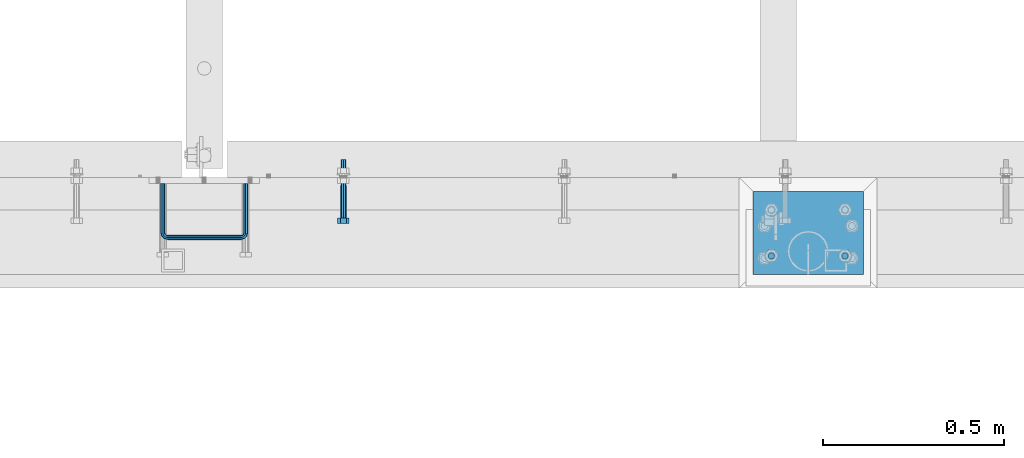
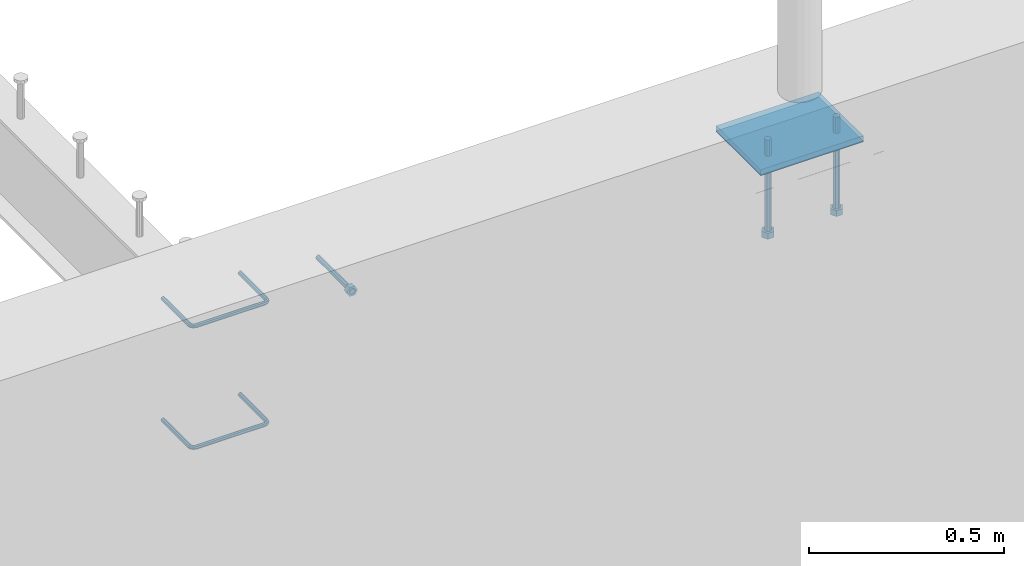
# One storey, part 402 of 975: 7 beams.
"""IFC2X3 building model written with IfcOpenShell, lengths in millimetres."""

from ifc_helpers import new_model, si_unit, frame, origin_with_axes, place, context, subcontext, project, spatial, faceted_brep, material, type_object, element, save


model = new_model("IFC2X3")

# Units and contexts
model_context = context("Model", 3, precision=1e-05, world=origin_with_axes())
body_context = subcontext(model_context, "Body", "Model", "MODEL_VIEW")
ifc_project = project(units=[si_unit("LENGTHUNIT", "METRE", prefix="MILLI"), si_unit("AREAUNIT", "SQUARE_METRE"), si_unit("VOLUMEUNIT", "CUBIC_METRE"), si_unit("MASSUNIT", "GRAM", prefix="KILO"), si_unit("TIMEUNIT", "SECOND"), si_unit("PLANEANGLEUNIT", "RADIAN"), si_unit("SOLIDANGLEUNIT", "STERADIAN"), si_unit("THERMODYNAMICTEMPERATUREUNIT", "DEGREE_CELSIUS"), si_unit("LUMINOUSINTENSITYUNIT", "LUMEN")], contexts=[model_context])

# Site, building, storey
site_placement = place(None, origin_with_axes())
site = spatial("IfcSite", under=ifc_project, at=site_placement, CompositionType="ELEMENT")
building_placement = place(site_placement, origin_with_axes())
building = spatial("IfcBuilding", under=site, at=building_placement, Name="Undefined", CompositionType="ELEMENT")
storey_placement = place(building_placement, origin_with_axes())
storey = spatial("IfcBuildingStorey", under=building, at=storey_placement, Name="Undefined", CompositionType="ELEMENT", Elevation=0.0)

# Beams
ifc_material_1 = material(Name="STEEL/F1554-36")
beam_type_1 = type_object("IfcBeamType", PredefinedType="NOTDEFINED")
beam_1_placement = place(storey_placement, frame((16405.225, 282.575000000001, 3886.2), z_axis=(0.0, 0.0, -1.0), x_axis=(0.0, -1.0, 0.0)))
element("IfcBeam", 1, at=beam_1_placement, inside=storey, type_object=beam_type_1, material=ifc_material_1, Name="HEADED_ANCHOR_BOLT", context=body_context, shape_type="Brep", body=[
    faceted_brep([(88.9000000184824, 7.94000001861696, -13.7499999799138), (88.8999999527368, 15.8800000758411, 2.00943759409711e-08), (104.774999952569, 15.8800001213949, 6.97191353538074e-08), (104.775000018315, 7.94000006417082, -13.7499999302891), (88.900000064019, -7.94000009583215, -13.7499999799147), (104.775000063852, -7.9400000502792, -13.74999993029), (88.9000000438027, -15.880000153059, 2.00925569515675e-08), (104.775000043643, -15.8800001075042, 6.9716406869702e-08), (88.8999999780608, -7.94000009583488, 13.7500000200998), (104.774999977893, -7.94000005028101, 13.7500000697237), (88.8999999325279, 7.94000001861514, 13.7500000201007), (104.774999932361, 7.940000064169, 13.7500000697246), (88.9000000119959, 3.78780480527439, -7.86545778426807), (88.8999999957159, 6.82538844544797, -5.4430656647246), (88.8999999799416, 8.51112018845743, -1.94260763148395), (88.8999999677944, 8.51112018845652, 1.94260767167179), (88.8999999616899, 6.82538844544615, 5.44306570491244), (88.8999999628249, 3.78780480527257, 7.86545782445592), (88.8999999709849, -3.86089595849626e-08, 8.72999956233434), (88.8999999845473, -3.7878048824914, 7.8654578244541), (88.9000000008309, -6.82538852266407, 5.44306570491153), (88.9000000166052, -8.51112026567444, 1.94260767166998), (88.9000000287488, -8.51112026567353, -1.94260763148577), (88.9000000348606, -6.82538852266407, -5.44306566472642), (88.9000000337182, -3.78780488248958, -7.86545778426898), (88.9000000255583, -3.86080500902608e-08, -8.72999952214832), (104.775000025395, 6.94581103743985e-09, -8.72999947252447), (104.775000011829, 3.78780485082825, -7.86545773464422), (104.774999995549, 6.82538849100092, -5.44306561510075), (104.774999979774, 8.51112023401038, -1.9426075818601), (104.774999967627, 8.51112023401038, 1.94260772129564), (104.774999961523, 6.82538849100092, 5.44306575453629), (104.774999962658, 3.78780485082643, 7.86545787407977), (104.774999970818, 6.94399204803631e-09, 8.7299996119591), (104.77499998438, -3.78780483693754, 7.86545787407886), (104.775000000664, -6.82538847711112, 5.44306575453538), (104.775000016438, -8.51112022012057, 1.94260772129473), (104.775000028581, -8.51112022012057, -1.94260758186101), (104.775000034693, -6.82538847711021, -5.44306561510166), (104.775000033551, -3.78780483693663, -7.86545773464422), (-2.99107341561466e-07, -5.61266007567065, 5.61266007566792), (-4.22995071858168e-07, -7.93750000000728, 0.0), (104.774999998088, -7.93749999999, -4.45652403868735e-11), (104.774999998088, -5.61266007565791, 5.61266007562426), (-1.09139364212751e-11, 1.81898940354586e-12, 7.9375), (104.774999998095, 1.18234311230481e-11, 7.93749999995816), (2.99089151667431e-07, 5.61266007567428, 5.61266007566792), (104.774999998102, 5.61266007568065, 5.61266007562517), (4.22980519942939e-07, 7.93750000001091, 0.0), (104.77499999811, 7.93750000001364, -4.36557456851006e-11), (2.99089151667431e-07, 5.61266007567428, -5.61266007566792), (104.774999998102, 5.61266007568156, -5.61266007571339), (-1.09139364212751e-11, 1.81898940354586e-12, -7.9375), (104.774999998099, 1.2732925824821e-11, -7.93750000004547), (-73.0249999592124, 5.05157065939329, -5.0515715445581), (-73.0249999269472, -1.85405951924622e-07, -7.14400069976364), (-73.0249999328516, -5.0515710302052, -5.05157154455992), (-73.0249999734697, -7.14400018541073, -6.9975976657588e-07), (-73.0250000250016, -5.05157103020611, 5.05157014504039), (-73.0250000572705, -1.85406861419324e-07, 7.1439993002441), (-73.0250000513661, 5.05157065939238, 5.05157014503948), (-73.025000010748, 7.14399981459792, -6.99758857081179e-07), (0.00625003290042514, 5.05157085007795, -5.05157087849238), (0.00625006516929716, 5.27870724909008e-09, -7.1440000336961), (0.00625005926485755, -5.05157083952145, -5.05157087849329), (0.00625001864682417, -7.14399999472516, -3.36940502165817e-08), (0.00624996711121639, -5.05157083952145, 5.05157081110519), (0.00624993484598235, 5.2777977543883e-09, 7.14399996631164), (0.00624994074678398, 5.05157085007704, 5.05157081110701), (0.00624998136845534, 7.14400000528167, -3.36922312271781e-08), (-2.99107341561466e-07, -5.61266007567065, -5.61266007566792), (104.774999998092, -5.612660075657, -5.6126600757143)], [[[0, 1, 2, 3]], [[4, 0, 3, 5]], [[6, 4, 5, 7]], [[8, 6, 7, 9]], [[10, 8, 9, 11]], [[0, 4, 6, 8, 10, 1], [12, 13, 14, 15, 16, 17, 18, 19, 20, 21, 22, 23, 24, 25]], [[12, 25, 26, 27]], [[13, 12, 27, 28]], [[14, 13, 28, 29]], [[15, 14, 29, 30]], [[16, 15, 30, 31]], [[17, 16, 31, 32]], [[18, 17, 32, 33]], [[19, 18, 33, 34]], [[20, 19, 34, 35]], [[21, 20, 35, 36]], [[22, 21, 36, 37]], [[23, 22, 37, 38]], [[24, 23, 38, 39]], [[25, 24, 39, 26]], [[9, 7, 5, 3, 2, 11], [38, 37, 36, 35, 34, 33, 32, 31, 30, 29, 28, 27, 26, 39]], [[1, 10, 11, 2]], [[40, 41, 42, 43]], [[44, 40, 43, 45]], [[46, 44, 45, 47]], [[48, 46, 47, 49]], [[50, 48, 49, 51]], [[52, 50, 51, 53]], [[54, 55, 56, 57, 58, 59, 60, 61]], [[55, 54, 62, 63]], [[56, 55, 63, 64]], [[57, 56, 64, 65]], [[58, 57, 65, 66]], [[59, 58, 66, 67]], [[60, 59, 67, 68]], [[61, 60, 68, 69]], [[54, 61, 69, 62]], [[40, 44, 46, 48, 50, 52, 70, 41], [68, 67, 66, 65, 64, 63, 62, 69]], [[41, 70, 71, 42]], [[53, 51, 49, 47, 45, 43, 42, 71]], [[70, 52, 53, 71]]]),
])
ifc_material_2 = material(Name="STEEL/A706")
beam_type_2 = type_object("IfcBeamType", Name="#4 TIE", PredefinedType="NOTDEFINED")
beam_2_placement = place(storey_placement, frame((16135.3500030518, 288.925, 3971.925), z_axis=(-0.999999999999998, 6.90000001668524e-08, 0.0), x_axis=(0.0, -1.0, 0.0)))
element("IfcBeam", 2, at=beam_2_placement, inside=storey, type_object=beam_type_2, material=ifc_material_2, Name="TIE ROD", ObjectType="#4 TIE", context=body_context, shape_type="Brep", body=[
    faceted_brep([(0.0, -6.34999999998763, -3.63797880709171e-12), (0.0, -4.49012806052269, -4.49012806054634), (136.525006144455, -4.49012806053452, -4.49012811661669), (136.525006146271, -6.35000000000036, -5.60821717954241e-08), (0.0, 7.27595761418343e-12, -6.35000000000764), (136.525006143703, 0.0, -6.35000005608254), (0.0, 4.49012806053724, -4.49012806053906), (136.525006144455, 4.49012806053452, -4.49012811661669), (0.0, 6.34999999999491, 5.45696821063757e-12), (136.525006146271, 6.35000000000036, -5.60821717954241e-08), (0.0, 4.49012806052633, 4.49012806054634), (136.525006148087, 4.49012806053452, 4.49012800445234), (0.0, 0.0, 6.35000000000764), (136.525006148839, 0.0, 6.34999994391819), (0.0, -4.49012806053361, 4.49012806053543), (136.525006148087, -4.49012806053452, 4.49012800445234), (146.050006113442, 0.0, -3.79778399058796), (145.120070138105, -4.49012806053452, -2.1870876464609), (142.875006094308, -6.35000000000036, 1.70147731239558), (140.62994205051, -4.49012806053452, 5.59004227125297), (139.700006075173, 0.0, 7.20073861538003), (140.62994205051, 4.49012806053452, 5.59004227125297), (142.875006094308, 6.35000000000036, 1.70147731239558), (145.120070138105, 4.49012806053452, -2.1870876464609), (151.412093644245, 4.49012806053452, 4.10493592790226), (153.022789998455, 0.0, 3.1749999700296), (147.523528661045, 6.35000000000036, 6.34999992953635), (143.634963677846, 4.49012806053452, 8.59506393117135), (142.024267323636, 0.0, 9.5249998890431), (143.634963677846, -4.49012806053452, 8.59506393117135), (147.523528661045, -6.35000000000036, 6.34999992953635), (151.412093644245, -4.49012806053452, 4.10493592790226), (153.715134021207, 4.49012806053452, 12.6999999465306), (155.575005960673, 0.0, 12.6999999674508), (149.225005960672, 6.35000000000036, 12.6999998960273), (144.734877900137, 4.49012806053452, 12.699999845524), (142.875005960672, 0.0, 12.6999998246056), (144.734877900137, -4.49012806053452, 12.699999845524), (149.225005960671, -6.35000000000036, 12.6999998960273), (153.715134021207, -4.49012806053452, 12.6999999465306), (153.71513173569, -4.49012806053452, 215.900003176369), (149.225003675155, -6.35000000000036, 215.900003125867), (155.575003675155, 0.0, 215.900003197289), (153.71513173569, 4.49012806053452, 215.900003176369), (149.225003675155, 6.35000000000036, 215.900003125867), (144.734875614621, 4.49012806053452, 215.900003075363), (142.875003675155, 0.0, 215.900003054444), (144.734875614621, -4.49012806053452, 215.900003075363), (153.022787648382, 0.0, 225.425002877988), (151.412091300475, -4.49012806053452, 224.495066909199), (147.523526332491, -6.35000000000036, 222.25000288121), (143.634961364508, -4.49012806053452, 220.004938853222), (142.024265016601, 0.0, 219.075002884432), (143.634961364508, 4.49012806053452, 220.004938853222), (147.523526332491, 6.35000000000036, 222.25000288121), (151.412091300475, 4.49012806053452, 224.495066909199), (145.120067985683, 4.49012806053452, 230.787090305822), (146.05000397542, 0.0, 232.397786641635), (142.875003907121, 6.35000000000036, 226.898525367037), (140.629939828559, 4.49012806053452, 223.00996042825), (139.700003838822, 0.0, 221.399264092438), (140.629939828559, -4.49012806053452, 223.00996042825), (142.875003907121, -6.35000000000036, 226.898525367037), (145.120067985683, -4.49012806053452, 230.787090305822), (136.525004282814, 4.49012806053452, 233.090130852819), (136.525004327922, 0.0, 234.950002792285), (136.525004173912, 6.35000000000036, 228.600002792285), (136.52500406501, 4.49012806053452, 224.10987473175), (136.525004019901, 0.0, 222.250002792285), (136.52500406501, -4.49012806053452, 224.10987473175), (136.525004173912, -6.35000000000036, 228.600002792286), (136.525004282814, -4.49012806053452, 233.090130852819), (3.32236731992452e-06, -4.49012806053452, 233.090134164055), (3.21346533382894e-06, -6.35000000000036, 228.60000610352), (3.36747552864836e-06, 0.0, 234.95000610352), (3.32236731992452e-06, 4.49012806053452, 233.090134164055), (3.21346533382894e-06, 6.35000000000036, 228.60000610352), (3.104562892986e-06, 4.49012806053452, 224.109878042986), (3.05945422951481e-06, 0.0, 222.25000610352), (3.104562892986e-06, -4.49012806053452, 224.109878042986)], [[[0, 1, 2, 3]], [[1, 4, 5, 2]], [[4, 6, 7, 5]], [[6, 8, 9, 7]], [[8, 10, 11, 9]], [[10, 12, 13, 11]], [[12, 14, 15, 13]], [[14, 0, 3, 15]], [[14, 12, 10, 8, 6, 4, 1, 0]], [[2, 5, 16, 17]], [[3, 2, 17, 18]], [[15, 3, 18, 19]], [[13, 15, 19, 20]], [[11, 13, 20, 21]], [[9, 11, 21, 22]], [[7, 9, 22, 23]], [[5, 7, 23, 16]], [[23, 24, 25, 16]], [[22, 26, 24, 23]], [[21, 27, 26, 22]], [[20, 28, 27, 21]], [[19, 29, 28, 20]], [[18, 30, 29, 19]], [[17, 31, 30, 18]], [[16, 25, 31, 17]], [[24, 32, 33, 25]], [[26, 34, 32, 24]], [[27, 35, 34, 26]], [[28, 36, 35, 27]], [[29, 37, 36, 28]], [[30, 38, 37, 29]], [[31, 39, 38, 30]], [[25, 33, 39, 31]], [[38, 39, 40, 41]], [[39, 33, 42, 40]], [[33, 32, 43, 42]], [[32, 34, 44, 43]], [[34, 35, 45, 44]], [[35, 36, 46, 45]], [[36, 37, 47, 46]], [[37, 38, 41, 47]], [[40, 42, 48, 49]], [[41, 40, 49, 50]], [[47, 41, 50, 51]], [[46, 47, 51, 52]], [[45, 46, 52, 53]], [[44, 45, 53, 54]], [[43, 44, 54, 55]], [[42, 43, 55, 48]], [[55, 56, 57, 48]], [[54, 58, 56, 55]], [[53, 59, 58, 54]], [[52, 60, 59, 53]], [[51, 61, 60, 52]], [[50, 62, 61, 51]], [[49, 63, 62, 50]], [[48, 57, 63, 49]], [[56, 64, 65, 57]], [[58, 66, 64, 56]], [[59, 67, 66, 58]], [[60, 68, 67, 59]], [[61, 69, 68, 60]], [[62, 70, 69, 61]], [[63, 71, 70, 62]], [[57, 65, 71, 63]], [[70, 71, 72, 73]], [[71, 65, 74, 72]], [[65, 64, 75, 74]], [[64, 66, 76, 75]], [[66, 67, 77, 76]], [[67, 68, 78, 77]], [[68, 69, 79, 78]], [[69, 70, 73, 79]], [[74, 75, 76, 77, 78, 79, 73, 72]]]),
])
beam_3_placement = place(storey_placement, frame((16135.3500030518, 288.925, 3590.92498779297), z_axis=(-0.999999999999998, 6.90000001668524e-08, 0.0), x_axis=(0.0, -1.0, 0.0)))
element("IfcBeam", 3, at=beam_3_placement, inside=storey, type_object=beam_type_2, material=ifc_material_2, Name="TIE ROD", ObjectType="#4 TIE", context=body_context, shape_type="Brep", body=[
    faceted_brep([(0.0, -6.34999999998763, -3.63797880709171e-12), (0.0, -4.49012806052269, -4.49012806054634), (136.525006144455, -4.49012806053452, -4.49012811661669), (136.525006146271, -6.35000000000036, -5.60821717954241e-08), (0.0, 7.27595761418343e-12, -6.35000000000764), (136.525006143703, 0.0, -6.35000005608254), (0.0, 4.49012806053724, -4.49012806053906), (136.525006144455, 4.49012806053452, -4.49012811661669), (0.0, 6.34999999999491, 5.45696821063757e-12), (136.525006146271, 6.35000000000036, -5.60821717954241e-08), (0.0, 4.49012806052633, 4.49012806054634), (136.525006148087, 4.49012806053452, 4.49012800445234), (0.0, 0.0, 6.35000000000764), (136.525006148839, 0.0, 6.34999994391819), (0.0, -4.49012806053361, 4.49012806053543), (136.525006148087, -4.49012806053452, 4.49012800445234), (146.050006113442, 0.0, -3.79778399058796), (145.120070138105, -4.49012806053452, -2.1870876464609), (142.875006094308, -6.35000000000036, 1.70147731239558), (140.62994205051, -4.49012806053452, 5.59004227125297), (139.700006075173, 0.0, 7.20073861538003), (140.62994205051, 4.49012806053452, 5.59004227125297), (142.875006094308, 6.35000000000036, 1.70147731239558), (145.120070138105, 4.49012806053452, -2.1870876464609), (151.412093644245, 4.49012806053452, 4.10493592790226), (153.022789998455, 0.0, 3.1749999700296), (147.523528661045, 6.35000000000036, 6.34999992953635), (143.634963677846, 4.49012806053452, 8.59506393117135), (142.024267323636, 0.0, 9.5249998890431), (143.634963677846, -4.49012806053452, 8.59506393117135), (147.523528661045, -6.35000000000036, 6.34999992953635), (151.412093644245, -4.49012806053452, 4.10493592790226), (153.715134021207, 4.49012806053452, 12.6999999465306), (155.575005960673, 0.0, 12.6999999674508), (149.225005960672, 6.35000000000036, 12.6999998960273), (144.734877900137, 4.49012806053452, 12.699999845524), (142.875005960672, 0.0, 12.6999998246056), (144.734877900137, -4.49012806053452, 12.699999845524), (149.225005960671, -6.35000000000036, 12.6999998960273), (153.715134021207, -4.49012806053452, 12.6999999465306), (153.71513173569, -4.49012806053452, 215.900003176369), (149.225003675155, -6.35000000000036, 215.900003125867), (155.575003675155, 0.0, 215.900003197289), (153.71513173569, 4.49012806053452, 215.900003176369), (149.225003675155, 6.35000000000036, 215.900003125867), (144.734875614621, 4.49012806053452, 215.900003075363), (142.875003675155, 0.0, 215.900003054444), (144.734875614621, -4.49012806053452, 215.900003075363), (153.022787648382, 0.0, 225.425002877988), (151.412091300475, -4.49012806053452, 224.495066909199), (147.523526332491, -6.35000000000036, 222.25000288121), (143.634961364508, -4.49012806053452, 220.004938853222), (142.024265016601, 0.0, 219.075002884432), (143.634961364508, 4.49012806053452, 220.004938853222), (147.523526332491, 6.35000000000036, 222.25000288121), (151.412091300475, 4.49012806053452, 224.495066909199), (145.120067985683, 4.49012806053452, 230.787090305822), (146.05000397542, 0.0, 232.397786641635), (142.875003907121, 6.35000000000036, 226.898525367037), (140.629939828559, 4.49012806053452, 223.00996042825), (139.700003838822, 0.0, 221.399264092438), (140.629939828559, -4.49012806053452, 223.00996042825), (142.875003907121, -6.35000000000036, 226.898525367037), (145.120067985683, -4.49012806053452, 230.787090305822), (136.525004282814, 4.49012806053452, 233.090130852819), (136.525004327922, 0.0, 234.950002792285), (136.525004173912, 6.35000000000036, 228.600002792285), (136.52500406501, 4.49012806053452, 224.10987473175), (136.525004019901, 0.0, 222.250002792285), (136.52500406501, -4.49012806053452, 224.10987473175), (136.525004173912, -6.35000000000036, 228.600002792286), (136.525004282814, -4.49012806053452, 233.090130852819), (3.32236731992452e-06, -4.49012806053452, 233.090134164055), (3.21346533382894e-06, -6.35000000000036, 228.60000610352), (3.36747552864836e-06, 0.0, 234.95000610352), (3.32236731992452e-06, 4.49012806053452, 233.090134164055), (3.21346533382894e-06, 6.35000000000036, 228.60000610352), (3.104562892986e-06, 4.49012806053452, 224.109878042986), (3.05945422951481e-06, 0.0, 222.25000610352), (3.104562892986e-06, -4.49012806053452, 224.109878042986)], [[[0, 1, 2, 3]], [[1, 4, 5, 2]], [[4, 6, 7, 5]], [[6, 8, 9, 7]], [[8, 10, 11, 9]], [[10, 12, 13, 11]], [[12, 14, 15, 13]], [[14, 0, 3, 15]], [[14, 12, 10, 8, 6, 4, 1, 0]], [[2, 5, 16, 17]], [[3, 2, 17, 18]], [[15, 3, 18, 19]], [[13, 15, 19, 20]], [[11, 13, 20, 21]], [[9, 11, 21, 22]], [[7, 9, 22, 23]], [[5, 7, 23, 16]], [[23, 24, 25, 16]], [[22, 26, 24, 23]], [[21, 27, 26, 22]], [[20, 28, 27, 21]], [[19, 29, 28, 20]], [[18, 30, 29, 19]], [[17, 31, 30, 18]], [[16, 25, 31, 17]], [[24, 32, 33, 25]], [[26, 34, 32, 24]], [[27, 35, 34, 26]], [[28, 36, 35, 27]], [[29, 37, 36, 28]], [[30, 38, 37, 29]], [[31, 39, 38, 30]], [[25, 33, 39, 31]], [[38, 39, 40, 41]], [[39, 33, 42, 40]], [[33, 32, 43, 42]], [[32, 34, 44, 43]], [[34, 35, 45, 44]], [[35, 36, 46, 45]], [[36, 37, 47, 46]], [[37, 38, 41, 47]], [[40, 42, 48, 49]], [[41, 40, 49, 50]], [[47, 41, 50, 51]], [[46, 47, 51, 52]], [[45, 46, 52, 53]], [[44, 45, 53, 54]], [[43, 44, 54, 55]], [[42, 43, 55, 48]], [[55, 56, 57, 48]], [[54, 58, 56, 55]], [[53, 59, 58, 54]], [[52, 60, 59, 53]], [[51, 61, 60, 52]], [[50, 62, 61, 51]], [[49, 63, 62, 50]], [[48, 57, 63, 49]], [[56, 64, 65, 57]], [[58, 66, 64, 56]], [[59, 67, 66, 58]], [[60, 68, 67, 59]], [[61, 69, 68, 60]], [[62, 70, 69, 61]], [[63, 71, 70, 62]], [[57, 65, 71, 63]], [[70, 71, 72, 73]], [[71, 65, 74, 72]], [[65, 64, 75, 74]], [[64, 66, 76, 75]], [[66, 67, 77, 76]], [[67, 68, 78, 77]], [[68, 69, 79, 78]], [[69, 70, 73, 79]], [[74, 75, 76, 77, 78, 79, 73, 72]]]),
])
beam_type_3 = type_object("IfcBeamType", PredefinedType="NOTDEFINED")
beam_4_placement = place(storey_placement, frame((17586.3249962077, 88.9000010438842, 3917.95), z_axis=(0.0, 1.0, 0.0), x_axis=(0.0, 0.0, -1.0)))
element("IfcBeam", 4, at=beam_4_placement, inside=storey, type_object=beam_type_3, material=ifc_material_1, Name="HEADED_BOLT", context=body_context, shape_type="Brep", body=[
    faceted_brep([(196.84375, -9.12999965559902, 15.8099993757314), (196.84375, -18.2599997700399, -1.0438852768857e-06), (215.893749999999, -18.2599997700399, -1.0438852768857e-06), (215.893749999999, -9.12999965559902, 15.8099993757314), (196.84375, 9.13000057328281, 15.8099993757314), (215.893749999999, 9.13000057328281, 15.8099993757314), (196.84375, 18.2600006877237, -1.0438852768857e-06), (215.893749999999, 18.2600006877237, -1.0438852768857e-06), (196.84375, 9.13000057328281, -15.810001463502), (215.893749999999, 9.13000057328281, -15.810001463502), (196.84375, -9.12999965559902, -15.810001463502), (215.893749999999, -9.12999965559902, -15.810001463502), (196.84375, -4.47767959644079, 9.2979973979138), (196.84375, -8.06850020163256, 6.43441352102286), (196.84375, -10.0612552973498, 2.29641492663589), (196.84375, -10.0612552973498, -2.29641701440644), (196.84375, -8.06850020163256, -6.43441560879344), (196.84375, -4.47767959644079, -9.29799948568439), (196.84375, 4.58841896033846e-07, -10.3200007387095), (196.84375, 4.47768051412459, -9.29799948568436), (196.84375, 8.06850111931635, -6.43441560879342), (196.84375, 10.0612562150336, -2.29641701440644), (196.84375, 10.0612562150336, 2.29641492663589), (196.84375, 8.06850111931635, 6.43441352102289), (196.84375, 4.47768051412459, 9.29799739791383), (196.84375, 4.58841896033846e-07, 10.3199986509389), (215.893749999999, 4.58841896033846e-07, 10.3199986509389), (215.893749999999, -4.47767959644079, 9.2979973979138), (215.893749999999, -8.06850020163256, 6.43441352102286), (215.893749999999, -10.0612552973498, 2.29641492663589), (215.893749999999, -10.0612552973498, -2.29641701440644), (215.893749999999, -8.06850020163256, -6.43441560879344), (215.893749999999, -4.47767959644079, -9.29799948568439), (215.893749999999, 4.58841896033846e-07, -10.3200007387095), (215.893749999999, 4.47768051412459, -9.29799948568436), (215.893749999999, 8.06850111931635, -6.43441560879342), (215.893749999999, 10.0612562150336, -2.29641701440644), (215.893749999999, 10.0612562150336, 2.29641492663589), (215.893749999999, 8.06850111931635, 6.43441352102289), (215.893749999999, 4.47768051412459, 9.29799739791383), (0.0, -6.73519209080223, 6.73519209080186), (0.0, -9.52499999999964, 0.0), (215.900000000001, -9.52499999999964, 0.0), (215.900000000001, -6.73519209080223, 6.73519209080186), (-9.87109982941227e-13, -1.20792265079217e-13, 9.52499961853027), (215.900000000001, 0.0, 9.52500000000001), (0.0, 6.73519209080223, 6.73519209080186), (215.900000000001, 6.73519209080223, 6.73519209080186), (0.0, 9.52499999999964, 0.0), (215.900000000001, 9.52499999999964, 0.0), (0.0, 6.73519209080223, -6.73519209080186), (215.900000000001, 6.73519209080223, -6.73519209080186), (2.95075507493764e-12, -1.20792265079217e-13, -9.52499961853027), (215.900000000001, 0.0, -9.52500000000001), (-88.9444446471748, -6.3639605718372, 6.39952908988423), (-88.9433906823501, 4.58841896033846e-07, 9.03556784850662), (-88.9444446471748, 6.36396148952099, 6.39952908988423), (-88.9469891433491, 9.0000004588419, 0.0355685678769078), (-88.9495336395235, 6.36396148952099, -6.32839195413041), (-88.9505876043481, 4.58841896033846e-07, -8.9644307127528), (-88.9495336395235, -6.3639605718372, -6.32839195413041), (-88.9469891433491, -8.9999995411581, 0.0355685678769078), (0.0124298302243915, 6.36396148952099, -6.36396152997716), (0.0113758653997138, 4.58841896033846e-07, -9.00000028859955), (0.0124298302243915, -6.3639605718372, -6.36396152997716), (0.0149743263987148, -8.9999995411581, -1.00796984270346e-06), (0.0175188225730381, -6.3639605718372, 6.36395951403748), (0.0185727873977157, 4.58841896033846e-07, 8.99999827265987), (0.0175188225730381, 6.36396148952099, 6.36395951403748), (0.0149743263987148, 9.0000004588419, -1.00796984270346e-06), (0.0, -6.73519209080223, -6.73519209080186), (215.900000000001, -6.73519209080223, -6.73519209080186)], [[[0, 1, 2, 3]], [[4, 0, 3, 5]], [[6, 4, 5, 7]], [[8, 6, 7, 9]], [[10, 8, 9, 11]], [[0, 4, 6, 8, 10, 1], [12, 13, 14, 15, 16, 17, 18, 19, 20, 21, 22, 23, 24, 25]], [[12, 25, 26, 27]], [[13, 12, 27, 28]], [[14, 13, 28, 29]], [[15, 14, 29, 30]], [[16, 15, 30, 31]], [[17, 16, 31, 32]], [[18, 17, 32, 33]], [[19, 18, 33, 34]], [[20, 19, 34, 35]], [[21, 20, 35, 36]], [[22, 21, 36, 37]], [[23, 22, 37, 38]], [[24, 23, 38, 39]], [[25, 24, 39, 26]], [[9, 7, 5, 3, 2, 11], [38, 37, 36, 35, 34, 33, 32, 31, 30, 29, 28, 27, 26, 39]], [[1, 10, 11, 2]], [[40, 41, 42, 43]], [[44, 40, 43, 45]], [[46, 44, 45, 47]], [[48, 46, 47, 49]], [[50, 48, 49, 51]], [[52, 50, 51, 53]], [[54, 55, 56, 57, 58, 59, 60, 61]], [[59, 58, 62, 63]], [[60, 59, 63, 64]], [[61, 60, 64, 65]], [[54, 61, 65, 66]], [[55, 54, 66, 67]], [[56, 55, 67, 68]], [[57, 56, 68, 69]], [[58, 57, 69, 62]], [[40, 44, 46, 48, 50, 52, 70, 41], [68, 67, 66, 65, 64, 63, 62, 69]], [[41, 70, 71, 42]], [[53, 51, 49, 47, 45, 43, 42, 71]], [[70, 52, 53, 71]]]),
])
beam_5_placement = place(storey_placement, frame((17789.5249962077, 88.9000010438842, 3917.95), z_axis=(0.0, 1.0, 0.0), x_axis=(0.0, 0.0, -1.0)))
element("IfcBeam", 5, at=beam_5_placement, inside=storey, type_object=beam_type_3, material=ifc_material_1, Name="HEADED_BOLT", context=body_context, shape_type="Brep", body=[
    faceted_brep([(196.84375, -9.12999965559902, 15.8099993757314), (196.84375, -18.2599997700399, -1.0438852768857e-06), (215.893749999999, -18.2599997700399, -1.0438852768857e-06), (215.893749999999, -9.12999965559902, 15.8099993757314), (196.84375, 9.13000057328281, 15.8099993757314), (215.893749999999, 9.13000057328281, 15.8099993757314), (196.84375, 18.2600006877237, -1.0438852768857e-06), (215.893749999999, 18.2600006877237, -1.0438852768857e-06), (196.84375, 9.13000057328281, -15.810001463502), (215.893749999999, 9.13000057328281, -15.810001463502), (196.84375, -9.12999965559902, -15.810001463502), (215.893749999999, -9.12999965559902, -15.810001463502), (196.84375, -4.47767959644079, 9.2979973979138), (196.84375, -8.06850020163256, 6.43441352102286), (196.84375, -10.0612552973498, 2.29641492663589), (196.84375, -10.0612552973498, -2.29641701440644), (196.84375, -8.06850020163256, -6.43441560879344), (196.84375, -4.47767959644079, -9.29799948568439), (196.84375, 4.58841896033846e-07, -10.3200007387095), (196.84375, 4.47768051412459, -9.29799948568436), (196.84375, 8.06850111931635, -6.43441560879342), (196.84375, 10.0612562150336, -2.29641701440644), (196.84375, 10.0612562150336, 2.29641492663589), (196.84375, 8.06850111931635, 6.43441352102289), (196.84375, 4.47768051412459, 9.29799739791383), (196.84375, 4.58841896033846e-07, 10.3199986509389), (215.893749999999, 4.58841896033846e-07, 10.3199986509389), (215.893749999999, -4.47767959644079, 9.2979973979138), (215.893749999999, -8.06850020163256, 6.43441352102286), (215.893749999999, -10.0612552973498, 2.29641492663589), (215.893749999999, -10.0612552973498, -2.29641701440644), (215.893749999999, -8.06850020163256, -6.43441560879344), (215.893749999999, -4.47767959644079, -9.29799948568439), (215.893749999999, 4.58841896033846e-07, -10.3200007387095), (215.893749999999, 4.47768051412459, -9.29799948568436), (215.893749999999, 8.06850111931635, -6.43441560879342), (215.893749999999, 10.0612562150336, -2.29641701440644), (215.893749999999, 10.0612562150336, 2.29641492663589), (215.893749999999, 8.06850111931635, 6.43441352102289), (215.893749999999, 4.47768051412459, 9.29799739791383), (0.0, -6.73519209080223, 6.73519209080186), (0.0, -9.52499999999964, 0.0), (215.900000000001, -9.52499999999964, 0.0), (215.900000000001, -6.73519209080223, 6.73519209080186), (-9.87109982941227e-13, -1.20792265079217e-13, 9.52499961853027), (215.900000000001, 0.0, 9.52500000000001), (0.0, 6.73519209080223, 6.73519209080186), (215.900000000001, 6.73519209080223, 6.73519209080186), (0.0, 9.52499999999964, 0.0), (215.900000000001, 9.52499999999964, 0.0), (0.0, 6.73519209080223, -6.73519209080186), (215.900000000001, 6.73519209080223, -6.73519209080186), (2.95075507493764e-12, -1.20792265079217e-13, -9.52499961853027), (215.900000000001, 0.0, -9.52500000000001), (-88.9444446471748, -6.3639605718372, 6.39952908988423), (-88.9433906823501, 4.58841896033846e-07, 9.03556784850662), (-88.9444446471748, 6.36396148952099, 6.39952908988423), (-88.9469891433491, 9.0000004588419, 0.0355685678769078), (-88.9495336395235, 6.36396148952099, -6.32839195413041), (-88.9505876043481, 4.58841896033846e-07, -8.9644307127528), (-88.9495336395235, -6.3639605718372, -6.32839195413041), (-88.9469891433491, -8.9999995411581, 0.0355685678769078), (0.0124298302243915, 6.36396148952099, -6.36396152997716), (0.0113758653997138, 4.58841896033846e-07, -9.00000028859955), (0.0124298302243915, -6.3639605718372, -6.36396152997716), (0.0149743263987148, -8.9999995411581, -1.00796984270346e-06), (0.0175188225730381, -6.3639605718372, 6.36395951403748), (0.0185727873977157, 4.58841896033846e-07, 8.99999827265987), (0.0175188225730381, 6.36396148952099, 6.36395951403748), (0.0149743263987148, 9.0000004588419, -1.00796984270346e-06), (0.0, -6.73519209080223, -6.73519209080186), (215.900000000001, -6.73519209080223, -6.73519209080186)], [[[0, 1, 2, 3]], [[4, 0, 3, 5]], [[6, 4, 5, 7]], [[8, 6, 7, 9]], [[10, 8, 9, 11]], [[0, 4, 6, 8, 10, 1], [12, 13, 14, 15, 16, 17, 18, 19, 20, 21, 22, 23, 24, 25]], [[12, 25, 26, 27]], [[13, 12, 27, 28]], [[14, 13, 28, 29]], [[15, 14, 29, 30]], [[16, 15, 30, 31]], [[17, 16, 31, 32]], [[18, 17, 32, 33]], [[19, 18, 33, 34]], [[20, 19, 34, 35]], [[21, 20, 35, 36]], [[22, 21, 36, 37]], [[23, 22, 37, 38]], [[24, 23, 38, 39]], [[25, 24, 39, 26]], [[9, 7, 5, 3, 2, 11], [38, 37, 36, 35, 34, 33, 32, 31, 30, 29, 28, 27, 26, 39]], [[1, 10, 11, 2]], [[40, 41, 42, 43]], [[44, 40, 43, 45]], [[46, 44, 45, 47]], [[48, 46, 47, 49]], [[50, 48, 49, 51]], [[52, 50, 51, 53]], [[54, 55, 56, 57, 58, 59, 60, 61]], [[59, 58, 62, 63]], [[60, 59, 63, 64]], [[61, 60, 64, 65]], [[54, 61, 65, 66]], [[55, 54, 66, 67]], [[56, 55, 67, 68]], [[57, 56, 68, 69]], [[58, 57, 69, 62]], [[40, 44, 46, 48, 50, 52, 70, 41], [68, 67, 66, 65, 64, 63, 62, 69]], [[41, 70, 71, 42]], [[53, 51, 49, 47, 45, 43, 42, 71]], [[70, 52, 53, 71]]]),
])
ifc_material_3 = material(Name="STEEL/A36")
beam_type_4 = type_object("IfcBeamType", PredefinedType="NOTDEFINED")
beam_6_placement = place(storey_placement, frame((17687.9249962077, 38.0999995180053, 3946.525), z_axis=(-0.999999999999998, 6.90000001668524e-08, 0.0), x_axis=(0.0, 1.0, 0.0)))
element("IfcBeam", 6, at=beam_6_placement, inside=storey, type_object=beam_type_4, material=ifc_material_3, Name="PLATE", context=body_context, shape_type="Brep", body=[
    faceted_brep([(0.0, 9.52499999999964, -152.4), (0.0, 9.52499999999964, 152.4), (228.600003051761, 9.52500000000009, 152.4), (228.600003051761, 9.52500000000009, -152.4), (0.0, -9.52499999999964, 152.4), (228.600003051761, -9.52500000000009, 152.4), (0.0, -9.52499999999964, -152.4), (228.600003051761, -9.52500000000009, -152.4)], [[[0, 1, 2, 3]], [[1, 4, 5, 2]], [[4, 6, 7, 5]], [[6, 0, 3, 7]], [[5, 7, 3, 2]], [[6, 4, 1, 0]]]),
])
beam_type_5 = type_object("IfcBeamType", PredefinedType="NOTDEFINED")
beam_7_placement = place(storey_placement, frame((17687.9249962077, 38.0999995180053, 3938.5875), z_axis=(-0.999999999999998, 6.90000001668524e-08, 0.0), x_axis=(0.0, 1.0, 0.0)))
element("IfcBeam", 7, at=beam_7_placement, inside=storey, type_object=beam_type_5, material=ifc_material_3, Name="TEMPLATE", context=body_context, shape_type="Brep", body=[
    faceted_brep([(0.0, 1.58750000000009, -152.4), (0.0, 1.58750000000009, 152.4), (228.600003051761, 1.58750000000009, 152.4), (228.600003051761, 1.58750000000009, -152.4), (0.0, -1.58750000000009, 152.4), (228.600003051761, -1.58750000000009, 152.4), (0.0, -1.58750000000009, -152.4), (228.600003051761, -1.58750000000009, -152.4)], [[[0, 1, 2, 3]], [[1, 4, 5, 2]], [[4, 6, 7, 5]], [[6, 0, 3, 7]], [[5, 7, 3, 2]], [[6, 4, 1, 0]]]),
])

save(model, "model.ifc")
